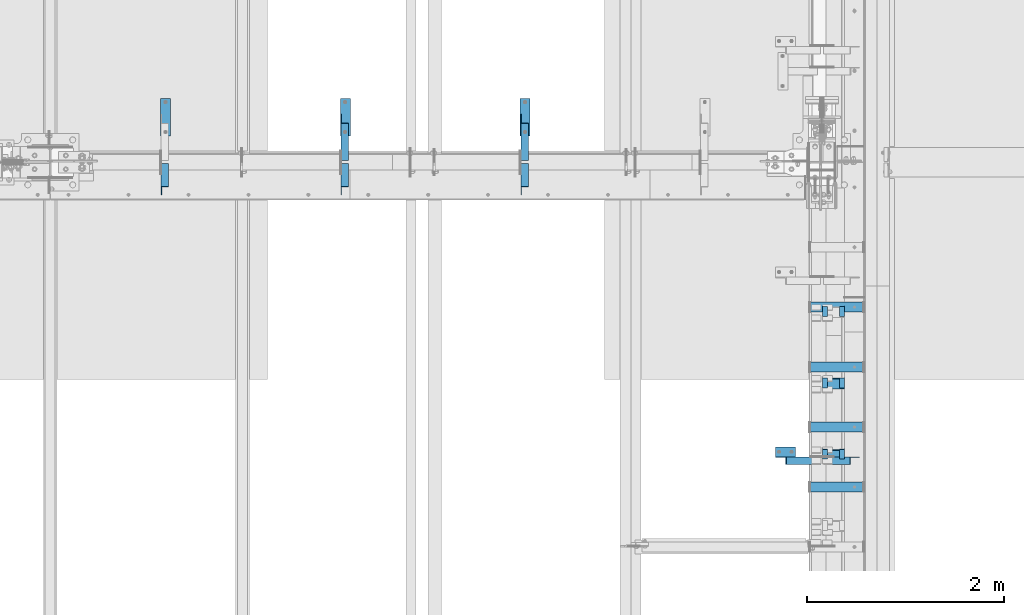
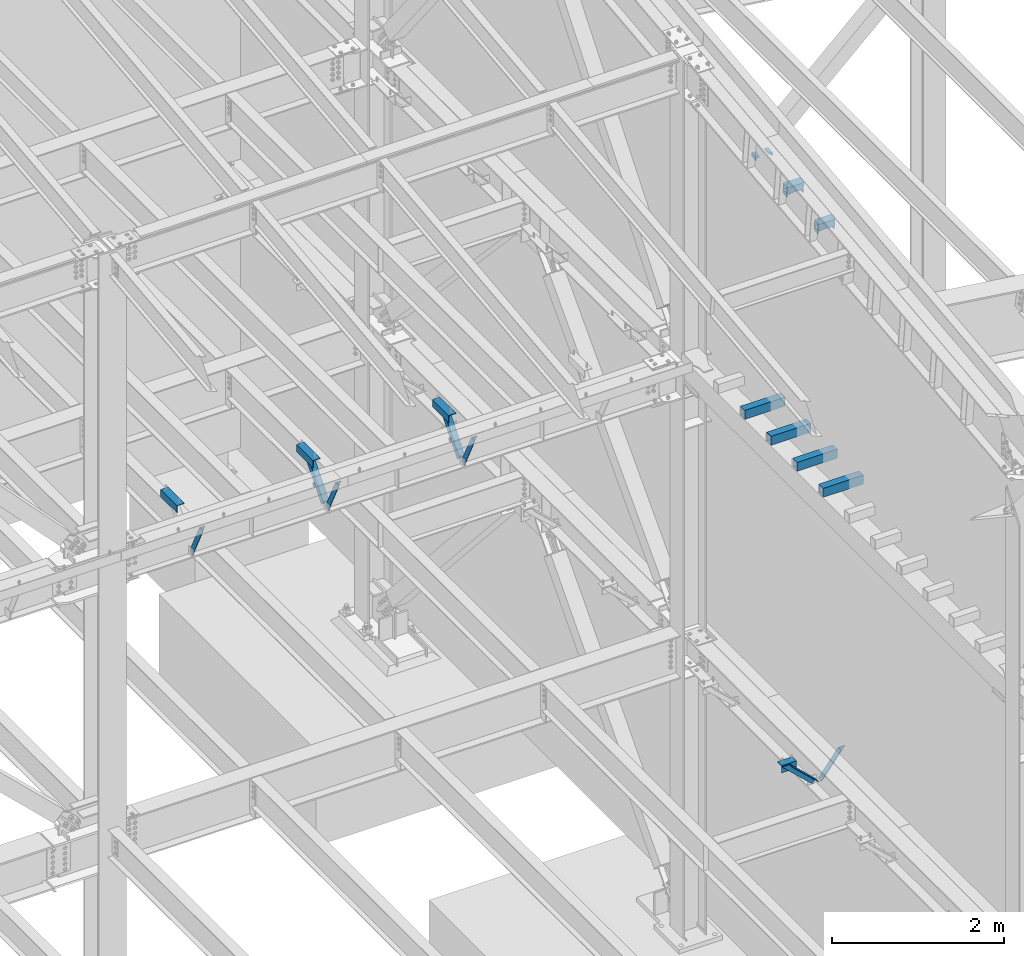
# One storey, part 842 of 1179: 16 beams, 7 members, 19 elements without a shape of their own.
"""IFC2X3 building model written with IfcOpenShell, lengths in millimetres."""

from ifc_helpers import new_model, si_unit, frame, origin_with_axes, place, context, subcontext, project, spatial, faceted_brep, material, type_object, element, aggregate, save


model = new_model("IFC2X3")

# Units and contexts
model_context = context("Model", 3, precision=1e-05, world=origin_with_axes())
body_context = subcontext(model_context, "Body", "Model", "MODEL_VIEW")
ifc_project = project(units=[si_unit("LENGTHUNIT", "METRE", prefix="MILLI"), si_unit("AREAUNIT", "SQUARE_METRE"), si_unit("VOLUMEUNIT", "CUBIC_METRE"), si_unit("MASSUNIT", "GRAM", prefix="KILO"), si_unit("TIMEUNIT", "SECOND"), si_unit("PLANEANGLEUNIT", "RADIAN"), si_unit("SOLIDANGLEUNIT", "STERADIAN"), si_unit("THERMODYNAMICTEMPERATUREUNIT", "DEGREE_CELSIUS"), si_unit("LUMINOUSINTENSITYUNIT", "LUMEN")], contexts=[model_context])

# Site, building, storey
site_placement = place(None, origin_with_axes())
site = spatial("IfcSite", under=ifc_project, at=site_placement, CompositionType="ELEMENT")
building_placement = place(site_placement, origin_with_axes())
building = spatial("IfcBuilding", under=site, at=building_placement, Name="Undefined", CompositionType="ELEMENT")
storey_placement = place(building_placement, origin_with_axes())
storey = spatial("IfcBuildingStorey", under=building, at=storey_placement, Name="Undefined", CompositionType="ELEMENT", Elevation=0.0)

# Assembly, member
assembly_1_placement = place(storey_placement, origin_with_axes())
assembly_1 = element("IfcElementAssembly", 1, at=assembly_1_placement, inside=storey, Name="ANGLE", AssemblyPlace="NOTDEFINED", PredefinedType="RIGID_FRAME")
ifc_material_1 = material(Name="STEEL/A36")
member_type = type_object("IfcMemberType", Name="L3X3X1/4", PredefinedType="NOTDEFINED")
member_1_placement = place(assembly_1_placement, frame((21283.6124995918, 27508.2, 8013.7), z_axis=(0.0, 0.7672237920886, -0.641379492074067), x_axis=(0.0, -0.641379492074066, -0.767223792088601)))
member_1 = element("IfcMember", 2, at=member_1_placement, type_object=member_type, material=ifc_material_1, Name="ANGLE", ObjectType="L3X3X1/4", context=body_context, shape_type="Brep", body=[
    faceted_brep([(52.5421123063024, 38.0999999999985, -38.0999999999967), (-11.159141226166, 38.0999999999985, 38.1000000000095), (634.651401994255, 38.0999999999985, 38.1000000003041), (634.651401994233, 38.0999999999985, -38.0999999997293), (-11.159141226166, 31.75, 38.1000000000095), (634.651401994255, 31.75, 38.1000000003041), (47.2336745119283, 31.75, -31.7499999999982), (634.651401994237, 31.75, -31.7499999997272), (47.2336745119283, -38.0999999999985, -31.7499999999982), (634.651401994237, -38.0999999999985, -31.7499999997272), (52.5421123063024, -38.0999999999985, -38.0999999999967), (634.651401994233, -38.0999999999985, -38.0999999997293)], [[[0, 1, 2, 3]], [[1, 4, 5, 2]], [[4, 6, 7, 5]], [[6, 8, 9, 7]], [[8, 10, 11, 9]], [[10, 0, 3, 11]], [[5, 7, 9, 11, 3, 2]], [[10, 8, 6, 4, 1, 0]]]),
])
aggregate(assembly_1, [member_1])

assembly_2_placement = place(storey_placement, origin_with_axes())
assembly_2 = element("IfcElementAssembly", 3, at=assembly_2_placement, inside=storey, Name="ANGLE", AssemblyPlace="NOTDEFINED", PredefinedType="RIGID_FRAME")
member_2_placement = place(assembly_2_placement, frame((19454.8124995918, 27508.2, 8013.7), z_axis=(0.0, 0.7672237920886, -0.641379492074067), x_axis=(0.0, -0.641379492074066, -0.767223792088601)))
member_2 = element("IfcMember", 4, at=member_2_placement, type_object=member_type, material=ifc_material_1, Name="ANGLE", ObjectType="L3X3X1/4", context=body_context, shape_type="Brep", body=[
    faceted_brep([(52.5421123063024, 38.0999999999985, -38.0999999999967), (-11.159141226166, 38.0999999999985, 38.1000000000095), (634.651401994255, 38.0999999999985, 38.1000000003041), (634.651401994233, 38.0999999999985, -38.0999999997293), (-11.159141226166, 31.75, 38.1000000000095), (634.651401994255, 31.75, 38.1000000003041), (47.2336745119283, 31.75, -31.7499999999982), (634.651401994237, 31.75, -31.7499999997272), (47.2336745119283, -38.0999999999985, -31.7499999999982), (634.651401994237, -38.0999999999985, -31.7499999997272), (52.5421123063024, -38.0999999999985, -38.0999999999967), (634.651401994233, -38.0999999999985, -38.0999999997293)], [[[0, 1, 2, 3]], [[1, 4, 5, 2]], [[4, 6, 7, 5]], [[6, 8, 9, 7]], [[8, 10, 11, 9]], [[10, 0, 3, 11]], [[5, 7, 9, 11, 3, 2]], [[10, 8, 6, 4, 1, 0]]]),
])
aggregate(assembly_2, [member_2])

assembly_3_placement = place(storey_placement, origin_with_axes())
assembly_3 = element("IfcElementAssembly", 5, at=assembly_3_placement, inside=storey, Name="ANGLE", AssemblyPlace="NOTDEFINED", PredefinedType="RIGID_FRAME")
member_3_placement = place(assembly_3_placement, frame((21283.6124995918, 27005.4961357473, 7519.97080646429), z_axis=(0.0, -0.897509848200057, -0.440994413098296), x_axis=(0.0, -0.440994413098296, 0.897509848200057)))
member_3 = element("IfcMember", 6, at=member_3_placement, type_object=member_type, material=ifc_material_1, Name="ANGLE", ObjectType="L3X3X1/4", context=body_context, shape_type="Brep", body=[
    faceted_brep([(0.0, 38.0999999999985, -38.0999999999999), (0.0, 38.0999999999985, 38.0999999999999), (568.830616953598, 38.0999999999985, 38.0999999992709), (531.389496563324, 38.0999999999985, -38.1000000007189), (0.0, 31.75, 38.1000000000004), (568.830616953598, 31.75, 38.0999999992709), (0.0, 31.75, -31.75), (534.509589929181, 31.75, -31.7500000007203), (0.0, -38.0999999999985, -31.75), (534.509589929181, -38.0999999999985, -31.7500000007203), (0.0, -38.0999999999985, -38.0999999999999), (531.389496563324, -38.0999999999985, -38.1000000007189)], [[[0, 1, 2, 3]], [[1, 4, 5, 2]], [[4, 6, 7, 5]], [[6, 8, 9, 7]], [[8, 10, 11, 9]], [[10, 0, 3, 11]], [[5, 7, 9, 11, 3, 2]], [[10, 8, 6, 4, 1, 0]]]),
])
aggregate(assembly_3, [member_3])

assembly_4_placement = place(storey_placement, origin_with_axes())
assembly_4 = element("IfcElementAssembly", 7, at=assembly_4_placement, inside=storey, Name="ANGLE", AssemblyPlace="NOTDEFINED", PredefinedType="RIGID_FRAME")
member_4_placement = place(assembly_4_placement, frame((19454.8124995918, 27005.4961357473, 7519.97080646429), z_axis=(0.0, -0.897509848200057, -0.440994413098296), x_axis=(0.0, -0.440994413098296, 0.897509848200057)))
member_4 = element("IfcMember", 8, at=member_4_placement, type_object=member_type, material=ifc_material_1, Name="ANGLE", ObjectType="L3X3X1/4", context=body_context, shape_type="Brep", body=[
    faceted_brep([(0.0, 38.0999999999985, -38.0999999999999), (0.0, 38.0999999999985, 38.0999999999999), (568.830616953598, 38.0999999999985, 38.0999999992709), (531.389496563324, 38.0999999999985, -38.1000000007189), (0.0, 31.75, 38.1000000000004), (568.830616953598, 31.75, 38.0999999992709), (0.0, 31.75, -31.75), (534.509589929181, 31.75, -31.7500000007203), (0.0, -38.0999999999985, -31.75), (534.509589929181, -38.0999999999985, -31.7500000007203), (0.0, -38.0999999999985, -38.0999999999999), (531.389496563324, -38.0999999999985, -38.1000000007189)], [[[0, 1, 2, 3]], [[1, 4, 5, 2]], [[4, 6, 7, 5]], [[6, 8, 9, 7]], [[8, 10, 11, 9]], [[10, 0, 3, 11]], [[5, 7, 9, 11, 3, 2]], [[10, 8, 6, 4, 1, 0]]]),
])
aggregate(assembly_4, [member_4])

assembly_5_placement = place(storey_placement, origin_with_axes())
assembly_5 = element("IfcElementAssembly", 9, at=assembly_5_placement, inside=storey, Name="ANGLE", AssemblyPlace="NOTDEFINED", PredefinedType="RIGID_FRAME")
member_5_placement = place(assembly_5_placement, frame((17626.0124995918, 27005.4961357473, 7519.97080646429), z_axis=(0.0, -0.897509848200057, -0.440994413098296), x_axis=(0.0, -0.440994413098296, 0.897509848200057)))
member_5 = element("IfcMember", 10, at=member_5_placement, type_object=member_type, material=ifc_material_1, Name="ANGLE", ObjectType="L3X3X1/4", context=body_context, shape_type="Brep", body=[
    faceted_brep([(0.0, 38.0999999999985, -38.0999999999999), (0.0, 38.0999999999985, 38.0999999999999), (568.830616953598, 38.0999999999985, 38.0999999992709), (531.389496563324, 38.0999999999985, -38.1000000007189), (0.0, 31.75, 38.1000000000004), (568.830616953598, 31.75, 38.0999999992709), (0.0, 31.75, -31.75), (534.509589929181, 31.75, -31.7500000007203), (0.0, -38.0999999999985, -31.75), (534.509589929181, -38.0999999999985, -31.7500000007203), (0.0, -38.0999999999985, -38.0999999999999), (531.389496563324, -38.0999999999985, -38.1000000007189)], [[[0, 1, 2, 3]], [[1, 4, 5, 2]], [[4, 6, 7, 5]], [[6, 8, 9, 7]], [[8, 10, 11, 9]], [[10, 0, 3, 11]], [[5, 7, 9, 11, 3, 2]], [[10, 8, 6, 4, 1, 0]]]),
])
aggregate(assembly_5, [member_5])

assembly_6_placement = place(storey_placement, origin_with_axes())
assembly_6 = element("IfcElementAssembly", 11, at=assembly_6_placement, inside=storey, Name="ANGLE", AssemblyPlace="NOTDEFINED", PredefinedType="RIGID_FRAME")
member_6_placement = place(assembly_6_placement, frame((23812.1150890972, 24015.7, 4162.88757791506), z_axis=(0.0, -1.0, 0.0), x_axis=(0.729484494811633, 0.0, -0.683997347823379)))
member_6 = element("IfcMember", 12, at=member_6_placement, type_object=member_type, material=ifc_material_1, Name="ANGLE", ObjectType="L3X3X1/4", context=body_context, shape_type="Brep", body=[
    faceted_brep([(148.072119708857, 38.1000000000204, -38.0999999999985), (148.072119708857, 38.1000000000204, 38.0999999999985), (623.824460863128, 38.1000000000349, 38.0999999999985), (623.824460863128, 38.1000000000349, -38.0999999999985), (141.299832423247, 31.7500000000182, 38.0999999999985), (623.824460863128, 31.7500000000291, 38.0999999999985), (141.299832423247, 31.7500000000182, -31.75), (623.824460863128, 31.7500000000291, -31.75), (66.8046722815307, -38.1000000000095, -31.75), (623.824460863132, -38.0999999999913, -31.75), (66.8046722815307, -38.1000000000095, -38.0999999999985), (623.824460863132, -38.0999999999913, -38.0999999999985)], [[[0, 1, 2, 3]], [[1, 4, 5, 2]], [[4, 6, 7, 5]], [[6, 8, 9, 7]], [[8, 10, 11, 9]], [[10, 0, 3, 11]], [[5, 7, 9, 11, 3, 2]], [[10, 8, 6, 4, 1, 0]]]),
])
aggregate(assembly_6, [member_6])

assembly_7_placement = place(storey_placement, origin_with_axes())
assembly_7 = element("IfcElementAssembly", 13, at=assembly_7_placement, inside=storey, Name="ANGLE", AssemblyPlace="NOTDEFINED", PredefinedType="RIGID_FRAME")
member_7_placement = place(assembly_7_placement, frame((24352.3014298031, 24015.7, 3731.6636484264), z_axis=(0.0, -1.0, 0.0), x_axis=(0.614083067285056, 0.0, 0.789241399366365)))
member_7 = element("IfcMember", 14, at=member_7_placement, type_object=member_type, material=ifc_material_1, Name="ANGLE", ObjectType="L3X3X1/4", context=body_context, shape_type="Brep", body=[
    faceted_brep([(0.0, 38.0999999999985, -38.0999999999999), (0.0, 38.0999999999985, 38.0999999999999), (439.713105507173, 38.1000000000386, 38.0999999999985), (439.713105507173, 38.1000000000386, -38.0999999999985), (0.0, 31.75, 38.1000000000004), (444.653834009747, 31.7500000000473, 38.0999999999985), (0.0, 31.75, -31.75), (444.653834009747, 31.7500000000473, -31.75), (0.0, -38.0999999999985, -31.75), (499.001847538042, -38.0999999998749, -31.75), (0.0, -38.0999999999985, -38.0999999999999), (499.001847538042, -38.0999999998749, -38.0999999999985)], [[[0, 1, 2, 3]], [[1, 4, 5, 2]], [[4, 6, 7, 5]], [[6, 8, 9, 7]], [[8, 10, 11, 9]], [[10, 0, 3, 11]], [[5, 7, 9, 11, 3, 2]], [[10, 8, 6, 4, 1, 0]]]),
])
aggregate(assembly_7, [member_7])

# Assembly, beam
assembly_8_placement = place(storey_placement, origin_with_axes())
assembly_8 = element("IfcElementAssembly", 15, at=assembly_8_placement, inside=storey, Name="BEAM", AssemblyPlace="NOTDEFINED", PredefinedType="RIGID_FRAME")
beam_type_1 = type_object("IfcBeamType", Name="L2X2X1/4", PredefinedType="NOTDEFINED")
beam_1_placement = place(assembly_8_placement, frame((24511.0, 25486.6067032332, 11692.1395405372), z_axis=(0.0, 0.112284087038014, -0.993676146336441), x_axis=(0.0, 0.993676146336441, 0.112284087038017)))
beam_1 = element("IfcBeam", 16, at=beam_1_placement, type_object=beam_type_1, material=ifc_material_1, Name="ANGLE", ObjectType="L2X2X1/4", context=body_context, shape_type="Brep", body=[
    faceted_brep([(0.0, 25.3999999999996, -25.4000000000015), (0.0, 25.3999999999996, 25.4000000000015), (101.599999999555, 25.4, 25.3999999999451), (101.599999999537, 25.4, -25.4000000000251), (7.27595761418343e-12, 19.05, 25.3999999999851), (101.599999999555, 19.05, 25.3999999999451), (0.0, 19.0499992350015, -19.0499992349996), (101.600003324515, 19.0499992350051, -19.0499992350015), (-1.09139364212751e-11, -25.4, -19.0499999999865), (101.59999999954, -25.4, -19.0500000000302), (0.0, -25.3999999999996, -25.4000000000015), (101.599999999537, -25.4, -25.4000000000251)], [[[0, 1, 2, 3]], [[1, 4, 5, 2]], [[4, 6, 7, 5]], [[6, 8, 9, 7]], [[8, 10, 11, 9]], [[10, 0, 3, 11]], [[5, 7, 9, 11, 3, 2]], [[10, 8, 6, 4, 1, 0]]]),
])

assembly_9_placement = place(storey_placement, origin_with_axes())
assembly_9 = element("IfcElementAssembly", 17, at=assembly_9_placement, inside=storey, Name="BEAM", AssemblyPlace="NOTDEFINED", PredefinedType="RIGID_FRAME")
beam_2_placement = place(assembly_9_placement, frame((24340.34375, 25486.6067032332, 11692.1395405372), z_axis=(1.0, 0.0, 0.0), x_axis=(0.0, 0.993676146336441, 0.112284087038017)))
beam_2 = element("IfcBeam", 18, at=beam_2_placement, type_object=beam_type_1, material=ifc_material_1, Name="ANGLE", ObjectType="L2X2X1/4", context=body_context, shape_type="Brep", body=[
    faceted_brep([(0.0, 25.3999999999996, -25.4000000000015), (0.0, 25.3999999999996, 25.4000000000015), (101.599999999555, 25.4, 25.3999999999451), (101.599999999537, 25.4, -25.4000000000251), (7.27595761418343e-12, 19.05, 25.3999999999851), (101.599999999555, 19.05, 25.3999999999451), (0.0, 19.0499992350015, -19.0499992349996), (101.600003324515, 19.0499992350051, -19.0499992350015), (-1.09139364212751e-11, -25.4, -19.0499999999865), (101.59999999954, -25.4, -19.0500000000302), (0.0, -25.3999999999996, -25.4000000000015), (101.599999999537, -25.4, -25.4000000000251)], [[[0, 1, 2, 3]], [[1, 4, 5, 2]], [[4, 6, 7, 5]], [[6, 8, 9, 7]], [[8, 10, 11, 9]], [[10, 0, 3, 11]], [[5, 7, 9, 11, 3, 2]], [[10, 8, 6, 4, 1, 0]]]),
])

# Beam
beam_3_placement = place(assembly_8_placement, frame((24511.0, 24760.6998413294, 11610.114383002), z_axis=(0.0, 0.112284087038014, -0.993676146336441), x_axis=(0.0, 0.993676146336441, 0.112284087038017)))
beam_3 = element("IfcBeam", 19, at=beam_3_placement, type_object=beam_type_1, material=ifc_material_1, Name="ANGLE", ObjectType="L2X2X1/4", context=body_context, shape_type="Brep", body=[
    faceted_brep([(0.0, 25.3999999999996, -25.4000000000015), (0.0, 25.3999999999996, 25.4000000000015), (101.599999999555, 25.4, 25.3999999999451), (101.599999999537, 25.4, -25.4000000000251), (7.27595761418343e-12, 19.05, 25.3999999999851), (101.599999999555, 19.05, 25.3999999999451), (0.0, 19.0499992350015, -19.0499992349996), (101.600003324515, 19.0499992350051, -19.0499992350015), (-1.09139364212751e-11, -25.4, -19.0499999999865), (101.59999999954, -25.4, -19.0500000000302), (0.0, -25.3999999999996, -25.4000000000015), (101.599999999537, -25.4, -25.4000000000251)], [[[0, 1, 2, 3]], [[1, 4, 5, 2]], [[4, 6, 7, 5]], [[6, 8, 9, 7]], [[8, 10, 11, 9]], [[10, 0, 3, 11]], [[5, 7, 9, 11, 3, 2]], [[10, 8, 6, 4, 1, 0]]]),
])

beam_4_placement = place(assembly_9_placement, frame((24340.34375, 24760.6998413294, 11610.1143830019), z_axis=(1.0, 0.0, 0.0), x_axis=(0.0, 0.993676146336441, 0.112284087038017)))
beam_4 = element("IfcBeam", 20, at=beam_4_placement, type_object=beam_type_1, material=ifc_material_1, Name="ANGLE", ObjectType="L2X2X1/4", context=body_context, shape_type="Brep", body=[
    faceted_brep([(0.0, 25.3999999999996, -25.4000000000015), (0.0, 25.3999999999996, 25.4000000000015), (101.599999999555, 25.4, 25.3999999999451), (101.599999999537, 25.4, -25.4000000000251), (7.27595761418343e-12, 19.05, 25.3999999999851), (101.599999999555, 19.05, 25.3999999999451), (0.0, 19.0499992350015, -19.0499992349996), (101.600003324515, 19.0499992350051, -19.0499992350015), (-1.09139364212751e-11, -25.4, -19.0499999999865), (101.59999999954, -25.4, -19.0500000000302), (0.0, -25.3999999999996, -25.4000000000015), (101.599999999537, -25.4, -25.4000000000251)], [[[0, 1, 2, 3]], [[1, 4, 5, 2]], [[4, 6, 7, 5]], [[6, 8, 9, 7]], [[8, 10, 11, 9]], [[10, 0, 3, 11]], [[5, 7, 9, 11, 3, 2]], [[10, 8, 6, 4, 1, 0]]]),
])

beam_5_placement = place(assembly_8_placement, frame((24511.0, 24034.8021705467, 11528.0077920088), z_axis=(0.0, 0.112284087038014, -0.993676146336441), x_axis=(0.0, 0.993676146336441, 0.112284087038017)))
beam_5 = element("IfcBeam", 21, at=beam_5_placement, type_object=beam_type_1, material=ifc_material_1, Name="ANGLE", ObjectType="L2X2X1/4", context=body_context, shape_type="Brep", body=[
    faceted_brep([(0.0, 25.3999999999996, -25.4000000000015), (0.0, 25.3999999999996, 25.4000000000015), (101.599999999555, 25.4, 25.3999999999451), (101.599999999537, 25.4, -25.4000000000251), (7.27595761418343e-12, 19.05, 25.3999999999851), (101.599999999555, 19.05, 25.3999999999451), (0.0, 19.0499992350015, -19.0499992349996), (101.600003324515, 19.0499992350051, -19.0499992350015), (-1.09139364212751e-11, -25.4, -19.0499999999865), (101.59999999954, -25.4, -19.0500000000302), (0.0, -25.3999999999996, -25.4000000000015), (101.599999999537, -25.4, -25.4000000000251)], [[[0, 1, 2, 3]], [[1, 4, 5, 2]], [[4, 6, 7, 5]], [[6, 8, 9, 7]], [[8, 10, 11, 9]], [[10, 0, 3, 11]], [[5, 7, 9, 11, 3, 2]], [[10, 8, 6, 4, 1, 0]]]),
])

aggregate(assembly_8, [beam_1, beam_3, beam_5])

beam_6_placement = place(assembly_9_placement, frame((24340.34375, 24034.8021705467, 11528.0077920088), z_axis=(1.0, 0.0, 0.0), x_axis=(0.0, 0.993676146336441, 0.112284087038017)))
beam_6 = element("IfcBeam", 22, at=beam_6_placement, type_object=beam_type_1, material=ifc_material_1, Name="ANGLE", ObjectType="L2X2X1/4", context=body_context, shape_type="Brep", body=[
    faceted_brep([(0.0, 25.3999999999996, -25.4000000000015), (0.0, 25.3999999999996, 25.4000000000015), (101.599999999555, 25.4, 25.3999999999451), (101.599999999537, 25.4, -25.4000000000251), (7.27595761418343e-12, 19.05, 25.3999999999851), (101.599999999555, 19.05, 25.3999999999451), (0.0, 19.0499992350015, -19.0499992349996), (101.600003324515, 19.0499992350051, -19.0499992350015), (-1.09139364212751e-11, -25.4, -19.0499999999865), (101.59999999954, -25.4, -19.0500000000302), (0.0, -25.3999999999996, -25.4000000000015), (101.599999999537, -25.4, -25.4000000000251)], [[[0, 1, 2, 3]], [[1, 4, 5, 2]], [[4, 6, 7, 5]], [[6, 8, 9, 7]], [[8, 10, 11, 9]], [[10, 0, 3, 11]], [[5, 7, 9, 11, 3, 2]], [[10, 8, 6, 4, 1, 0]]]),
])

aggregate(assembly_9, [beam_2, beam_4, beam_6])

# Assembly, beam
assembly_10_placement = place(storey_placement, origin_with_axes())
assembly_10 = element("IfcElementAssembly", 23, at=assembly_10_placement, inside=storey, Name="ANGLE", AssemblyPlace="NOTDEFINED", PredefinedType="RIGID_FRAME")
beam_type_2 = type_object("IfcBeamType", Name="L4X4X1/4", PredefinedType="NOTDEFINED")
beam_7_placement = place(assembly_10_placement, frame((21289.9624995918, 27317.6213553416, 7962.9), z_axis=(1.0, 0.0, 0.0), x_axis=(0.0, 1.0, 0.0)))
beam_7 = element("IfcBeam", 24, at=beam_7_placement, type_object=beam_type_2, material=ifc_material_1, Name="ANGLE", ObjectType="L4X4X1/4", context=body_context, shape_type="Brep", body=[
    faceted_brep([(1.90993887372315e-11, 50.8000000000002, -50.8000000000002), (1.90993887372315e-11, 50.8000000000002, 50.8000000000002), (381.0, 50.8000000000002, 50.7999999999993), (381.0, 50.8000000000002, -50.7999999999993), (0.0, 44.4500000000007, 50.8000000000002), (381.0, 44.4499999999998, 50.7999999999993), (0.0, 44.4500000000007, -44.4499999999998), (381.0, 44.4499999999998, -44.4500000000007), (0.0, -50.7999999999993, -44.4499999999998), (381.0, -50.8000000000002, -44.4500000000007), (-1.81898940354586e-11, -50.7999999999997, -50.8000000000002), (381.0, -50.8000000000002, -50.7999999999993)], [[[0, 1, 2, 3]], [[1, 4, 5, 2]], [[4, 6, 7, 5]], [[6, 8, 9, 7]], [[8, 10, 11, 9]], [[10, 0, 3, 11]], [[5, 7, 9, 11, 3, 2]], [[10, 8, 6, 4, 1, 0]]]),
])
aggregate(assembly_10, [beam_7])

assembly_11_placement = place(storey_placement, origin_with_axes())
assembly_11 = element("IfcElementAssembly", 25, at=assembly_11_placement, inside=storey, Name="ANGLE", AssemblyPlace="NOTDEFINED", PredefinedType="RIGID_FRAME")
beam_8_placement = place(assembly_11_placement, frame((19461.1624995918, 27317.6213553416, 7962.9), z_axis=(1.0, 0.0, 0.0), x_axis=(0.0, 1.0, 0.0)))
beam_8 = element("IfcBeam", 26, at=beam_8_placement, type_object=beam_type_2, material=ifc_material_1, Name="ANGLE", ObjectType="L4X4X1/4", context=body_context, shape_type="Brep", body=[
    faceted_brep([(1.90993887372315e-11, 50.8000000000002, -50.8000000000002), (1.90993887372315e-11, 50.8000000000002, 50.8000000000002), (381.0, 50.8000000000002, 50.7999999999993), (381.0, 50.8000000000002, -50.7999999999993), (0.0, 44.4500000000007, 50.8000000000002), (381.0, 44.4499999999998, 50.7999999999993), (0.0, 44.4500000000007, -44.4499999999998), (381.0, 44.4499999999998, -44.4500000000007), (0.0, -50.7999999999993, -44.4499999999998), (381.0, -50.8000000000002, -44.4500000000007), (-1.81898940354586e-11, -50.7999999999997, -50.8000000000002), (381.0, -50.8000000000002, -50.7999999999993)], [[[0, 1, 2, 3]], [[1, 4, 5, 2]], [[4, 6, 7, 5]], [[6, 8, 9, 7]], [[8, 10, 11, 9]], [[10, 0, 3, 11]], [[5, 7, 9, 11, 3, 2]], [[10, 8, 6, 4, 1, 0]]]),
])
aggregate(assembly_11, [beam_8])

assembly_12_placement = place(storey_placement, origin_with_axes())
assembly_12 = element("IfcElementAssembly", 27, at=assembly_12_placement, inside=storey, Name="ANGLE", AssemblyPlace="NOTDEFINED", PredefinedType="RIGID_FRAME")
beam_9_placement = place(assembly_12_placement, frame((17632.3624995918, 27317.6213553416, 7962.9), z_axis=(1.0, 0.0, 0.0), x_axis=(0.0, 1.0, 0.0)))
beam_9 = element("IfcBeam", 28, at=beam_9_placement, type_object=beam_type_2, material=ifc_material_1, Name="ANGLE", ObjectType="L4X4X1/4", context=body_context, shape_type="Brep", body=[
    faceted_brep([(1.90993887372315e-11, 50.8000000000002, -50.8000000000002), (1.90993887372315e-11, 50.8000000000002, 50.8000000000002), (381.0, 50.8000000000002, 50.7999999999993), (381.0, 50.8000000000002, -50.7999999999993), (0.0, 44.4500000000007, 50.8000000000002), (381.0, 44.4499999999998, 50.7999999999993), (0.0, 44.4500000000007, -44.4499999999998), (381.0, 44.4499999999998, -44.4500000000007), (0.0, -50.7999999999993, -44.4499999999998), (381.0, -50.8000000000002, -44.4500000000007), (-1.81898940354586e-11, -50.7999999999997, -50.8000000000002), (381.0, -50.8000000000002, -50.7999999999993)], [[[0, 1, 2, 3]], [[1, 4, 5, 2]], [[4, 6, 7, 5]], [[6, 8, 9, 7]], [[8, 10, 11, 9]], [[10, 0, 3, 11]], [[5, 7, 9, 11, 3, 2]], [[10, 8, 6, 4, 1, 0]]]),
])
aggregate(assembly_12, [beam_9])

assembly_13_placement = place(storey_placement, origin_with_axes())
assembly_13 = element("IfcElementAssembly", 29, at=assembly_13_placement, inside=storey, Name="ANGLE", AssemblyPlace="NOTDEFINED", PredefinedType="RIGID_FRAME")
beam_10_placement = place(assembly_13_placement, frame((23834.8036446584, 24104.6, 4051.3), z_axis=(0.0, 0.0, -1.0), x_axis=(1.0, 0.0, 0.0)))
beam_10 = element("IfcBeam", 30, at=beam_10_placement, type_object=beam_type_2, material=ifc_material_1, Name="ANGLE", ObjectType="L4X4X1/4", context=body_context, shape_type="Brep", body=[
    faceted_brep([(1.90993887372315e-11, 50.8000000000002, -50.8000000000002), (1.90993887372315e-11, 50.8000000000002, 50.8000000000002), (203.200000000001, 50.7999999999993, 50.8000000000002), (203.200000000001, 50.7999999999993, -50.8000000000002), (0.0, 44.4500000000007, 50.8000000000002), (203.200000000001, 44.4500000000007, 50.8000000000002), (0.0, 44.4500000000007, -44.4499999999998), (203.200000000001, 44.4500000000007, -44.4499999999998), (0.0, -50.7999999999993, -44.4499999999998), (203.200000000001, -50.7999999999993, -44.4499999999998), (-1.81898940354586e-11, -50.7999999999997, -50.8000000000002), (203.200000000001, -50.7999999999993, -50.8000000000002)], [[[0, 1, 2, 3]], [[1, 4, 5, 2]], [[4, 6, 7, 5]], [[6, 8, 9, 7]], [[8, 10, 11, 9]], [[10, 0, 3, 11]], [[5, 7, 9, 11, 3, 2]], [[10, 8, 6, 4, 1, 0]]]),
])
aggregate(assembly_13, [beam_10])

assembly_14_placement = place(storey_placement, origin_with_axes())
assembly_14 = element("IfcElementAssembly", 31, at=assembly_14_placement, inside=storey, Name="BEAM", AssemblyPlace="NOTDEFINED", PredefinedType="RIGID_FRAME")
ifc_material_2 = material()
beam_type_3 = type_object("IfcBeamType", Name="HSS4X4X5/16", PredefinedType="NOTDEFINED")
beam_11_placement = place(assembly_14_placement, frame((24307.8, 24802.6225421309, 11691.5365369741), z_axis=(0.0, -0.112284087038017, 0.993676146336441), x_axis=(1.0, 0.0, 0.0)))
beam_11 = element("IfcBeam", 32, at=beam_11_placement, type_object=beam_type_3, material=ifc_material_2, Name="BEAM", ObjectType="HSS4X4X5/16", context=body_context, shape_type="Brep", body=[
    faceted_brep([(7.14374999999757, 42.8624999999884, -42.8624999999574), (7.14374999999757, -42.8624999999593, -42.862499999992), (228.600000000002, -42.8624999999593, -42.862499999992), (228.600000000002, 42.8624999999884, -42.8624999999574), (7.14374999999757, -42.8624999999956, 42.8624999999611), (228.600000000002, -42.8624999999956, 42.8624999999611), (7.14374999999757, 42.862499999952, 42.8624999999938), (228.600000000002, 42.862499999952, 42.8624999999938), (7.14374999999757, 50.7999999999884, -50.7999999999502), (7.14374999999757, 50.7999999999447, 50.7999999999938), (228.600000000002, 50.7999999999447, 50.7999999999938), (228.600000000002, 50.7999999999884, -50.7999999999502), (7.14374999999757, -50.7999999999956, 50.799999999952), (228.600000000002, -50.7999999999956, 50.799999999952), (7.14374999999757, -50.7999999999556, -50.7999999999902), (228.600000000002, -50.7999999999556, -50.7999999999902)], [[[0, 1, 2, 3]], [[1, 4, 5, 2]], [[4, 6, 7, 5]], [[6, 0, 3, 7]], [[8, 9, 10, 11]], [[9, 12, 13, 10]], [[12, 14, 15, 13]], [[14, 8, 11, 15]], [[13, 15, 11, 10], [5, 7, 3, 2]], [[14, 12, 9, 8], [6, 4, 1, 0]]]),
])
aggregate(assembly_14, [beam_11])

assembly_15_placement = place(storey_placement, origin_with_axes())
assembly_15 = element("IfcElementAssembly", 33, at=assembly_15_placement, inside=storey, Name="BEAM", AssemblyPlace="NOTDEFINED", PredefinedType="RIGID_FRAME")
beam_12_placement = place(assembly_15_placement, frame((24307.8, 24076.7248713482, 11609.429945981), z_axis=(0.0, -0.112284087038017, 0.993676146336441), x_axis=(1.0, 0.0, 0.0)))
beam_12 = element("IfcBeam", 34, at=beam_12_placement, type_object=beam_type_3, material=ifc_material_2, Name="BEAM", ObjectType="HSS4X4X5/16", context=body_context, shape_type="Brep", body=[
    faceted_brep([(7.14374999999757, 42.8624999999884, -42.8624999999574), (7.14374999999757, -42.8624999999593, -42.862499999992), (228.600000000002, -42.8624999999593, -42.862499999992), (228.600000000002, 42.8624999999884, -42.8624999999574), (7.14374999999757, -42.8624999999956, 42.8624999999611), (228.600000000002, -42.8624999999956, 42.8624999999611), (7.14374999999757, 42.862499999952, 42.8624999999938), (228.600000000002, 42.862499999952, 42.8624999999938), (7.14374999999757, 50.7999999999884, -50.7999999999502), (7.14374999999757, 50.7999999999447, 50.7999999999938), (228.600000000002, 50.7999999999447, 50.7999999999938), (228.600000000002, 50.7999999999884, -50.7999999999502), (7.14374999999757, -50.7999999999956, 50.799999999952), (228.600000000002, -50.7999999999956, 50.799999999952), (7.14374999999757, -50.7999999999556, -50.7999999999902), (228.600000000002, -50.7999999999556, -50.7999999999902)], [[[0, 1, 2, 3]], [[1, 4, 5, 2]], [[4, 6, 7, 5]], [[6, 0, 3, 7]], [[8, 9, 10, 11]], [[9, 12, 13, 10]], [[12, 14, 15, 13]], [[14, 8, 11, 15]], [[13, 15, 11, 10], [5, 7, 3, 2]], [[14, 12, 9, 8], [6, 4, 1, 0]]]),
])
aggregate(assembly_15, [beam_12])

assembly_16_placement = place(storey_placement, origin_with_axes())
assembly_16 = element("IfcElementAssembly", 35, at=assembly_16_placement, inside=storey, Name="BEAM", AssemblyPlace="NOTDEFINED", PredefinedType="RIGID_FRAME")
beam_type_4 = type_object("IfcBeamType", Name="HSS5X4X3/8", PredefinedType="NOTDEFINED")
beam_13_placement = place(assembly_16_placement, frame((24180.8, 25577.8, 8077.19999998781), z_axis=(0.0, 0.0, 1.0), x_axis=(1.0, 0.0, 0.0)))
beam_13 = element("IfcBeam", 36, at=beam_13_placement, type_object=beam_type_4, material=ifc_material_2, Name="BEAM", ObjectType="HSS5X4X3/8", context=body_context, shape_type="Brep", body=[
    faceted_brep([(9.52500000000146, 41.2750000000015, -53.9750000000004), (9.52500000000146, -41.2750000000015, -53.9750000000004), (549.274999999994, -41.2750000000015, -53.9750000000004), (549.274999999994, 41.2750000000015, -53.9750000000004), (9.52500000000146, -41.2750000000015, 53.9750000000004), (549.274999999994, -41.2750000000015, 53.9750000000004), (9.52500000000146, 41.2750000000015, 53.9750000000004), (549.274999999994, 41.2750000000015, 53.9750000000004), (9.52500000000146, 50.7999999999993, -63.5), (9.52500000000146, 50.7999999999993, 63.5), (549.274999999994, 50.7999999999993, 63.5), (549.274999999994, 50.7999999999993, -63.5), (9.52500000000146, -50.7999999999993, 63.5), (549.274999999994, -50.7999999999993, 63.5), (9.52500000000146, -50.7999999999993, -63.5), (549.274999999994, -50.7999999999993, -63.5)], [[[0, 1, 2, 3]], [[1, 4, 5, 2]], [[4, 6, 7, 5]], [[6, 0, 3, 7]], [[8, 9, 10, 11]], [[9, 12, 13, 10]], [[12, 14, 15, 13]], [[14, 8, 11, 15]], [[13, 15, 11, 10], [5, 7, 3, 2]], [[14, 12, 9, 8], [6, 4, 1, 0]]]),
])
aggregate(assembly_16, [beam_13])

assembly_17_placement = place(storey_placement, origin_with_axes())
assembly_17 = element("IfcElementAssembly", 37, at=assembly_17_placement, inside=storey, Name="BEAM", AssemblyPlace="NOTDEFINED", PredefinedType="RIGID_FRAME")
beam_14_placement = place(assembly_17_placement, frame((24180.8, 24968.2, 8077.19999998781), z_axis=(0.0, 0.0, 1.0), x_axis=(1.0, 0.0, 0.0)))
beam_14 = element("IfcBeam", 38, at=beam_14_placement, type_object=beam_type_4, material=ifc_material_2, Name="BEAM", ObjectType="HSS5X4X3/8", context=body_context, shape_type="Brep", body=[
    faceted_brep([(9.52500000000146, 41.2750000000015, -53.9750000000004), (9.52500000000146, -41.2750000000015, -53.9750000000004), (549.274999999994, -41.2750000000015, -53.9750000000004), (549.274999999994, 41.2750000000015, -53.9750000000004), (9.52500000000146, -41.2750000000015, 53.9750000000004), (549.274999999994, -41.2750000000015, 53.9750000000004), (9.52500000000146, 41.2750000000015, 53.9750000000004), (549.274999999994, 41.2750000000015, 53.9750000000004), (9.52500000000146, 50.7999999999993, -63.5), (9.52500000000146, 50.7999999999993, 63.5), (549.274999999994, 50.7999999999993, 63.5), (549.274999999994, 50.7999999999993, -63.5), (9.52500000000146, -50.7999999999993, 63.5), (549.274999999994, -50.7999999999993, 63.5), (9.52500000000146, -50.7999999999993, -63.5), (549.274999999994, -50.7999999999993, -63.5)], [[[0, 1, 2, 3]], [[1, 4, 5, 2]], [[4, 6, 7, 5]], [[6, 0, 3, 7]], [[8, 9, 10, 11]], [[9, 12, 13, 10]], [[12, 14, 15, 13]], [[14, 8, 11, 15]], [[13, 15, 11, 10], [5, 7, 3, 2]], [[14, 12, 9, 8], [6, 4, 1, 0]]]),
])
aggregate(assembly_17, [beam_14])

assembly_18_placement = place(storey_placement, origin_with_axes())
assembly_18 = element("IfcElementAssembly", 39, at=assembly_18_placement, inside=storey, Name="BEAM", AssemblyPlace="NOTDEFINED", PredefinedType="RIGID_FRAME")
beam_15_placement = place(assembly_18_placement, frame((24180.8, 24358.6, 8077.19999998781), z_axis=(0.0, 0.0, 1.0), x_axis=(1.0, 0.0, 0.0)))
beam_15 = element("IfcBeam", 40, at=beam_15_placement, type_object=beam_type_4, material=ifc_material_2, Name="BEAM", ObjectType="HSS5X4X3/8", context=body_context, shape_type="Brep", body=[
    faceted_brep([(9.52500000000146, 41.2750000000015, -53.9750000000004), (9.52500000000146, -41.2750000000015, -53.9750000000004), (549.274999999994, -41.2750000000015, -53.9750000000004), (549.274999999994, 41.2750000000015, -53.9750000000004), (9.52500000000146, -41.2750000000015, 53.9750000000004), (549.274999999994, -41.2750000000015, 53.9750000000004), (9.52500000000146, 41.2750000000015, 53.9750000000004), (549.274999999994, 41.2750000000015, 53.9750000000004), (9.52500000000146, 50.7999999999993, -63.5), (9.52500000000146, 50.7999999999993, 63.5), (549.274999999994, 50.7999999999993, 63.5), (549.274999999994, 50.7999999999993, -63.5), (9.52500000000146, -50.7999999999993, 63.5), (549.274999999994, -50.7999999999993, 63.5), (9.52500000000146, -50.7999999999993, -63.5), (549.274999999994, -50.7999999999993, -63.5)], [[[0, 1, 2, 3]], [[1, 4, 5, 2]], [[4, 6, 7, 5]], [[6, 0, 3, 7]], [[8, 9, 10, 11]], [[9, 12, 13, 10]], [[12, 14, 15, 13]], [[14, 8, 11, 15]], [[13, 15, 11, 10], [5, 7, 3, 2]], [[14, 12, 9, 8], [6, 4, 1, 0]]]),
])
aggregate(assembly_18, [beam_15])

assembly_19_placement = place(storey_placement, origin_with_axes())
assembly_19 = element("IfcElementAssembly", 41, at=assembly_19_placement, inside=storey, Name="BEAM", AssemblyPlace="NOTDEFINED", PredefinedType="RIGID_FRAME")
beam_16_placement = place(assembly_19_placement, frame((24180.8, 23749.0, 8077.19999998781), z_axis=(0.0, 0.0, 1.0), x_axis=(1.0, 0.0, 0.0)))
beam_16 = element("IfcBeam", 42, at=beam_16_placement, type_object=beam_type_4, material=ifc_material_2, Name="BEAM", ObjectType="HSS5X4X3/8", context=body_context, shape_type="Brep", body=[
    faceted_brep([(9.52500000000146, 41.2750000000015, -53.9750000000004), (9.52500000000146, -41.2750000000015, -53.9750000000004), (549.274999999994, -41.2750000000015, -53.9750000000004), (549.274999999994, 41.2750000000015, -53.9750000000004), (9.52500000000146, -41.2750000000015, 53.9750000000004), (549.274999999994, -41.2750000000015, 53.9750000000004), (9.52500000000146, 41.2750000000015, 53.9750000000004), (549.274999999994, 41.2750000000015, 53.9750000000004), (9.52500000000146, 50.7999999999993, -63.5), (9.52500000000146, 50.7999999999993, 63.5), (549.274999999994, 50.7999999999993, 63.5), (549.274999999994, 50.7999999999993, -63.5), (9.52500000000146, -50.7999999999993, 63.5), (549.274999999994, -50.7999999999993, 63.5), (9.52500000000146, -50.7999999999993, -63.5), (549.274999999994, -50.7999999999993, -63.5)], [[[0, 1, 2, 3]], [[1, 4, 5, 2]], [[4, 6, 7, 5]], [[6, 0, 3, 7]], [[8, 9, 10, 11]], [[9, 12, 13, 10]], [[12, 14, 15, 13]], [[14, 8, 11, 15]], [[13, 15, 11, 10], [5, 7, 3, 2]], [[14, 12, 9, 8], [6, 4, 1, 0]]]),
])
aggregate(assembly_19, [beam_16])

save(model, "model.ifc")
